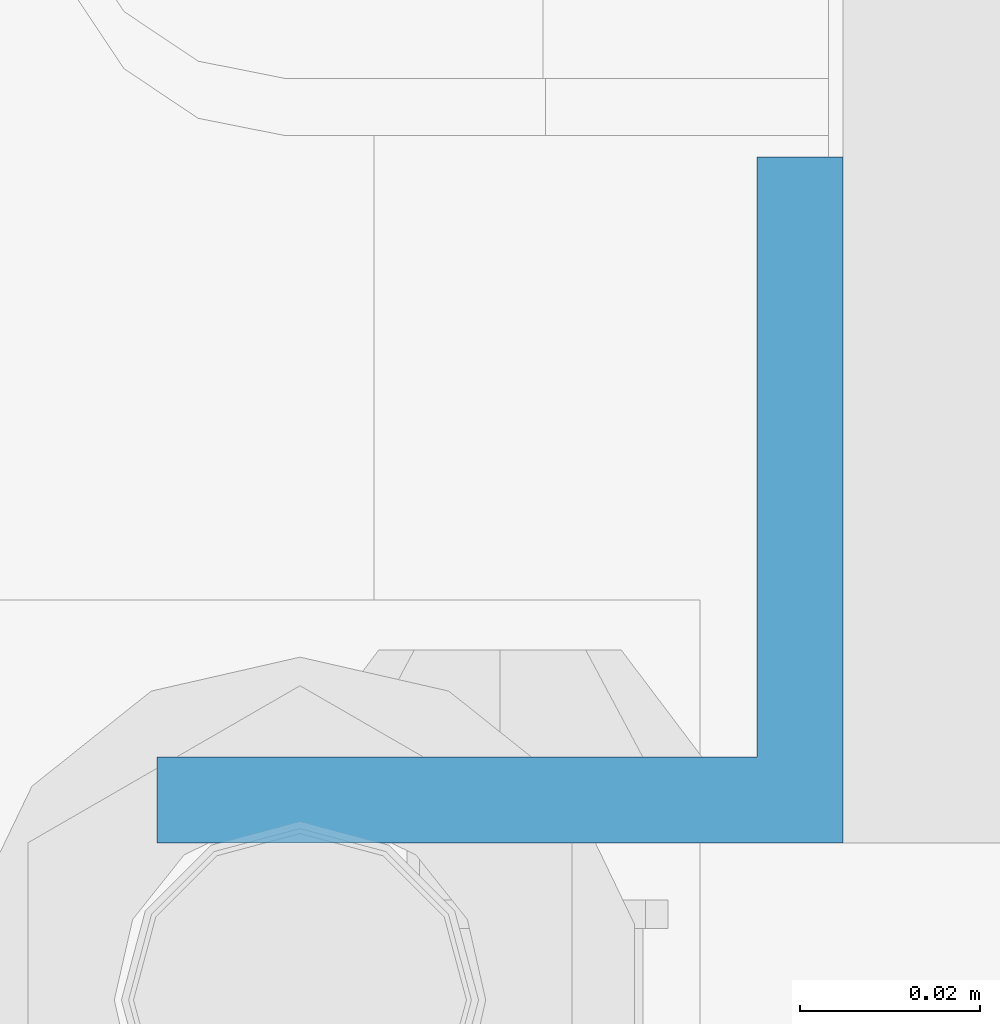
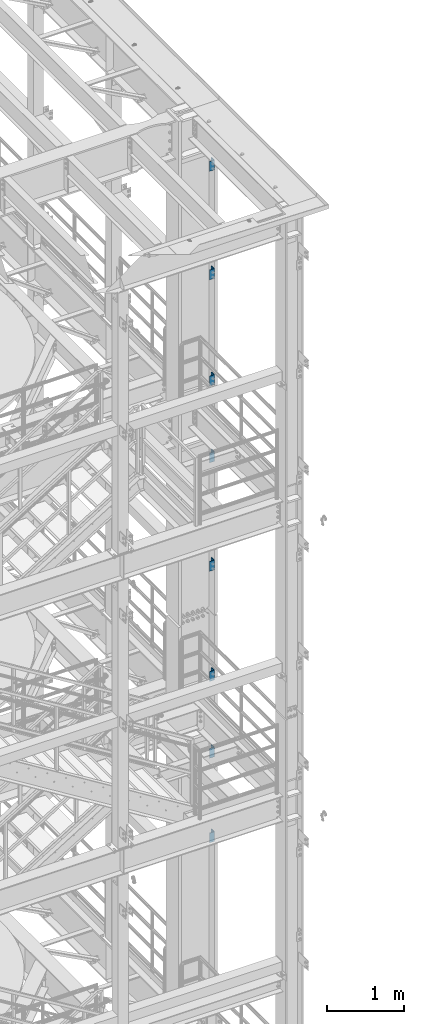
# One storey, part 831 of 1876: 8 columns, 2 elements without a shape of their own.
"""IFC2X3 building model written with IfcOpenShell, lengths in millimetres."""

from ifc_helpers import new_model, si_unit, frame, origin_with_axes, place, context, subcontext, project, spatial, faceted_brep, material, type_object, element, aggregate, save


model = new_model("IFC2X3")

# Units and contexts
model_context = context("Model", 3, precision=1e-05, world=origin_with_axes())
body_context = subcontext(model_context, "Body", "Model", "MODEL_VIEW")
ifc_project = project(units=[si_unit("LENGTHUNIT", "METRE", prefix="MILLI"), si_unit("AREAUNIT", "SQUARE_METRE"), si_unit("VOLUMEUNIT", "CUBIC_METRE"), si_unit("MASSUNIT", "GRAM", prefix="KILO"), si_unit("TIMEUNIT", "SECOND"), si_unit("PLANEANGLEUNIT", "RADIAN"), si_unit("SOLIDANGLEUNIT", "STERADIAN"), si_unit("THERMODYNAMICTEMPERATUREUNIT", "DEGREE_CELSIUS"), si_unit("LUMINOUSINTENSITYUNIT", "LUMEN")], contexts=[model_context])

# Site, building, storey
site_placement = place(None, origin_with_axes())
site = spatial("IfcSite", under=ifc_project, at=site_placement, CompositionType="ELEMENT")
building_placement = place(site_placement, origin_with_axes())
building = spatial("IfcBuilding", under=site, at=building_placement, Name="Undefined", CompositionType="ELEMENT")
storey_placement = place(building_placement, origin_with_axes())
storey = spatial("IfcBuildingStorey", under=building, at=storey_placement, Name="Undefined", CompositionType="ELEMENT", Elevation=0.0)

# Assembly, columns
assembly_1_placement = place(storey_placement, origin_with_axes())
assembly_1 = element("IfcElementAssembly", 1, at=assembly_1_placement, inside=storey, Name="COLUMN", AssemblyPlace="NOTDEFINED", PredefinedType="RIGID_FRAME")
ifc_material = material(Name="STEEL/A36")
column_type = type_object("IfcColumnType", Name="L3X3X3/8", PredefinedType="NOTDEFINED")
column_1_placement = place(assembly_1_placement, frame((7832.725, -4694.2375, 21602.7), z_axis=(0.0, 1.0, 0.0), x_axis=(0.0, 0.0, 1.0)))
column_1 = element("IfcColumn", 2, at=column_1_placement, type_object=column_type, material=ifc_material, Name="ANGLE", ObjectType="L3X3X3/8", context=body_context, shape_type="Brep", body=[
    faceted_brep([(0.0, 38.1000000000004, -38.1), (0.0, 38.1000000000004, 38.1), (152.4, 38.1000000000004, 38.1), (152.4, 38.1000000000004, -38.1), (0.0, 28.5749999999998, 38.1), (152.4, 28.5749999999998, 38.1), (0.0, 28.5749999999998, -28.575), (152.4, 28.5749999999998, -28.575), (0.0, -38.1000000000004, -28.575), (152.4, -38.1000000000004, -28.575), (0.0, -38.1000000000004, -38.1), (152.4, -38.1000000000004, -38.1)], [[[0, 1, 2, 3]], [[1, 4, 5, 2]], [[4, 6, 7, 5]], [[6, 8, 9, 7]], [[8, 10, 11, 9]], [[10, 0, 3, 11]], [[5, 7, 9, 11, 3, 2]], [[10, 8, 6, 4, 1, 0]]]),
])
column_2_placement = place(assembly_1_placement, frame((7832.725, -4694.2375, 19881.85), z_axis=(0.0, 1.0, 0.0), x_axis=(0.0, 0.0, 1.0)))
column_2 = element("IfcColumn", 3, at=column_2_placement, type_object=column_type, material=ifc_material, Name="ANGLE", ObjectType="L3X3X3/8", context=body_context, shape_type="Brep", body=[
    faceted_brep([(0.0, 38.1000000000004, -38.1), (0.0, 38.1000000000004, 38.1), (152.4, 38.1000000000004, 38.1), (152.4, 38.1000000000004, -38.1), (0.0, 28.5749999999998, 38.1), (152.4, 28.5749999999998, 38.1), (0.0, 28.5749999999998, -28.575), (152.4, 28.5749999999998, -28.575), (0.0, -38.1000000000004, -28.575), (152.4, -38.1000000000004, -28.575), (0.0, -38.1000000000004, -38.1), (152.4, -38.1000000000004, -38.1)], [[[0, 1, 2, 3]], [[1, 4, 5, 2]], [[4, 6, 7, 5]], [[6, 8, 9, 7]], [[8, 10, 11, 9]], [[10, 0, 3, 11]], [[5, 7, 9, 11, 3, 2]], [[10, 8, 6, 4, 1, 0]]]),
])
column_3_placement = place(assembly_1_placement, frame((7832.725, -4694.2375, 18199.1), z_axis=(0.0, 1.0, 0.0), x_axis=(0.0, 0.0, 1.0)))
column_3 = element("IfcColumn", 4, at=column_3_placement, type_object=column_type, material=ifc_material, Name="ANGLE", ObjectType="L3X3X3/8", context=body_context, shape_type="Brep", body=[
    faceted_brep([(0.0, 38.1000000000004, -38.1), (0.0, 38.1000000000004, 38.1), (152.4, 38.1000000000004, 38.1), (152.4, 38.1000000000004, -38.1), (0.0, 28.5749999999998, 38.1), (152.4, 28.5749999999998, 38.1), (0.0, 28.5749999999998, -28.575), (152.4, 28.5749999999998, -28.575), (0.0, -38.1000000000004, -28.575), (152.4, -38.1000000000004, -28.575), (0.0, -38.1000000000004, -38.1), (152.4, -38.1000000000004, -38.1)], [[[0, 1, 2, 3]], [[1, 4, 5, 2]], [[4, 6, 7, 5]], [[6, 8, 9, 7]], [[8, 10, 11, 9]], [[10, 0, 3, 11]], [[5, 7, 9, 11, 3, 2]], [[10, 8, 6, 4, 1, 0]]]),
])
column_4_placement = place(assembly_1_placement, frame((7832.725, -4694.2375, 16979.9), z_axis=(0.0, 1.0, 0.0), x_axis=(0.0, 0.0, 1.0)))
column_4 = element("IfcColumn", 5, at=column_4_placement, type_object=column_type, material=ifc_material, Name="ANGLE", ObjectType="L3X3X3/8", context=body_context, shape_type="Brep", body=[
    faceted_brep([(0.0, 38.1000000000004, -38.1), (0.0, 38.1000000000004, 38.1), (152.4, 38.1000000000004, 38.1), (152.4, 38.1000000000004, -38.1), (0.0, 28.5749999999998, 38.1), (152.4, 28.5749999999998, 38.1), (0.0, 28.5749999999998, -28.575), (152.4, 28.5749999999998, -28.575), (0.0, -38.1000000000004, -28.575), (152.4, -38.1000000000004, -28.575), (0.0, -38.1000000000004, -38.1), (152.4, -38.1000000000004, -38.1)], [[[0, 1, 2, 3]], [[1, 4, 5, 2]], [[4, 6, 7, 5]], [[6, 8, 9, 7]], [[8, 10, 11, 9]], [[10, 0, 3, 11]], [[5, 7, 9, 11, 3, 2]], [[10, 8, 6, 4, 1, 0]]]),
])
column_5_placement = place(assembly_1_placement, frame((7832.725, -4694.2375, 15259.05), z_axis=(0.0, 1.0, 0.0), x_axis=(0.0, 0.0, 1.0)))
column_5 = element("IfcColumn", 6, at=column_5_placement, type_object=column_type, material=ifc_material, Name="ANGLE", ObjectType="L3X3X3/8", context=body_context, shape_type="Brep", body=[
    faceted_brep([(0.0, 38.1000000000004, -38.1), (0.0, 38.1000000000004, 38.1), (152.4, 38.1000000000004, 38.1), (152.4, 38.1000000000004, -38.1), (0.0, 28.5749999999998, 38.1), (152.4, 28.5749999999998, 38.1), (0.0, 28.5749999999998, -28.575), (152.4, 28.5749999999998, -28.575), (0.0, -38.1000000000004, -28.575), (152.4, -38.1000000000004, -28.575), (0.0, -38.1000000000004, -38.1), (152.4, -38.1000000000004, -38.1)], [[[0, 1, 2, 3]], [[1, 4, 5, 2]], [[4, 6, 7, 5]], [[6, 8, 9, 7]], [[8, 10, 11, 9]], [[10, 0, 3, 11]], [[5, 7, 9, 11, 3, 2]], [[10, 8, 6, 4, 1, 0]]]),
])
aggregate(assembly_1, [column_1, column_2, column_3, column_4, column_5])

assembly_2_placement = place(storey_placement, origin_with_axes())
assembly_2 = element("IfcElementAssembly", 7, at=assembly_2_placement, inside=storey, Name="COLUMN", AssemblyPlace="NOTDEFINED", PredefinedType="RIGID_FRAME")
column_6_placement = place(assembly_2_placement, frame((7832.725, -4694.2375, 13512.8), z_axis=(0.0, 1.0, 0.0), x_axis=(0.0, 0.0, 1.0)))
column_6 = element("IfcColumn", 8, at=column_6_placement, type_object=column_type, material=ifc_material, Name="ANGLE", ObjectType="L3X3X3/8", context=body_context, shape_type="Brep", body=[
    faceted_brep([(0.0, 38.1000000000004, -38.1), (0.0, 38.1000000000004, 38.1), (152.4, 38.1000000000004, 38.1), (152.4, 38.1000000000004, -38.1), (0.0, 28.5749999999998, 38.1), (152.4, 28.5749999999998, 38.1), (0.0, 28.5749999999998, -28.575), (152.4, 28.5749999999998, -28.575), (0.0, -38.1000000000004, -28.575), (152.4, -38.1000000000004, -28.575), (0.0, -38.1000000000004, -38.1), (152.4, -38.1000000000004, -38.1)], [[[0, 1, 2, 3]], [[1, 4, 5, 2]], [[4, 6, 7, 5]], [[6, 8, 9, 7]], [[8, 10, 11, 9]], [[10, 0, 3, 11]], [[5, 7, 9, 11, 3, 2]], [[10, 8, 6, 4, 1, 0]]]),
])
column_7_placement = place(assembly_2_placement, frame((7832.725, -4694.2375, 12293.6), z_axis=(0.0, 1.0, 0.0), x_axis=(0.0, 0.0, 1.0)))
column_7 = element("IfcColumn", 9, at=column_7_placement, type_object=column_type, material=ifc_material, Name="ANGLE", ObjectType="L3X3X3/8", context=body_context, shape_type="Brep", body=[
    faceted_brep([(0.0, 38.1000000000004, -38.1), (0.0, 38.1000000000004, 38.1), (152.4, 38.1000000000004, 38.1), (152.4, 38.1000000000004, -38.1), (0.0, 28.5749999999998, 38.1), (152.4, 28.5749999999998, 38.1), (0.0, 28.5749999999998, -28.575), (152.4, 28.5749999999998, -28.575), (0.0, -38.1000000000004, -28.575), (152.4, -38.1000000000004, -28.575), (0.0, -38.1000000000004, -38.1), (152.4, -38.1000000000004, -38.1)], [[[0, 1, 2, 3]], [[1, 4, 5, 2]], [[4, 6, 7, 5]], [[6, 8, 9, 7]], [[8, 10, 11, 9]], [[10, 0, 3, 11]], [[5, 7, 9, 11, 3, 2]], [[10, 8, 6, 4, 1, 0]]]),
])
column_8_placement = place(assembly_2_placement, frame((7832.725, -4694.2375, 10953.75), z_axis=(0.0, 1.0, 0.0), x_axis=(0.0, 0.0, 1.0)))
column_8 = element("IfcColumn", 10, at=column_8_placement, type_object=column_type, material=ifc_material, Name="ANGLE", ObjectType="L3X3X3/8", context=body_context, shape_type="Brep", body=[
    faceted_brep([(0.0, 38.1000000000004, -38.1), (0.0, 38.1000000000004, 38.1), (152.4, 38.1000000000004, 38.1), (152.4, 38.1000000000004, -38.1), (0.0, 28.5749999999998, 38.1), (152.4, 28.5749999999998, 38.1), (0.0, 28.5749999999998, -28.575), (152.4, 28.5749999999998, -28.575), (0.0, -38.1000000000004, -28.575), (152.4, -38.1000000000004, -28.575), (0.0, -38.1000000000004, -38.1), (152.4, -38.1000000000004, -38.1)], [[[0, 1, 2, 3]], [[1, 4, 5, 2]], [[4, 6, 7, 5]], [[6, 8, 9, 7]], [[8, 10, 11, 9]], [[10, 0, 3, 11]], [[5, 7, 9, 11, 3, 2]], [[10, 8, 6, 4, 1, 0]]]),
])
aggregate(assembly_2, [column_6, column_7, column_8])

save(model, "model.ifc")
